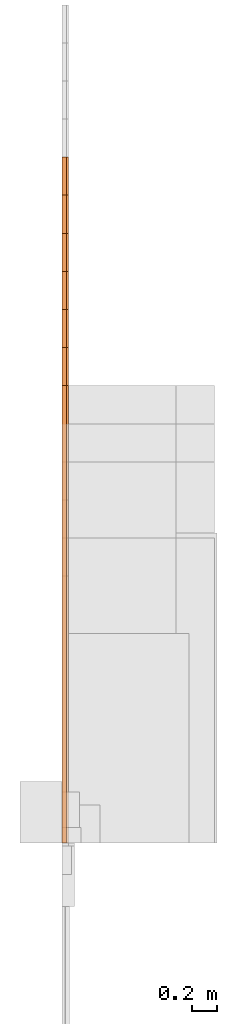
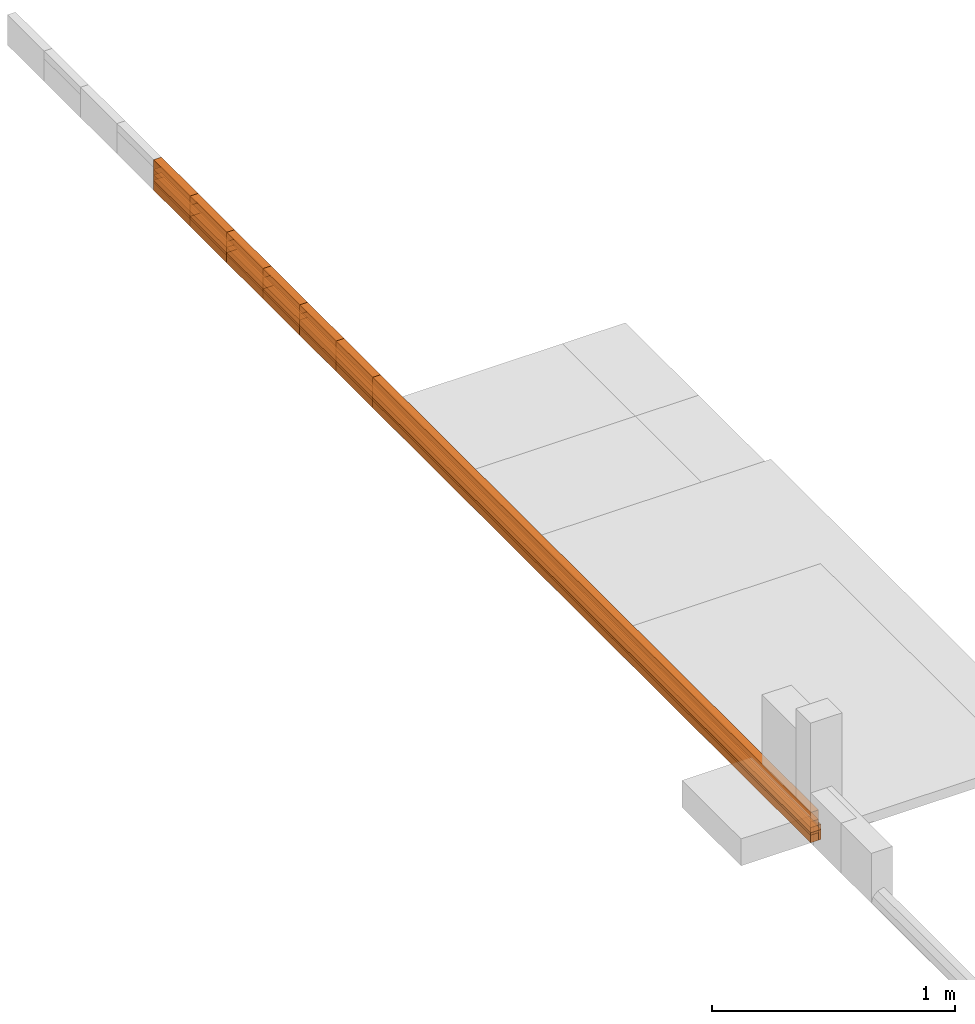
# Not in any storey, part 3 of 5: 43 proxies.
"""IFC4 model written with IfcOpenShell, lengths in metres."""

from ifc_helpers import new_model, entity, si_unit, converted_unit, direction, origin_with_axes, place, context, subcontext, project, faceted_brep, element, save


model = new_model("IFC4")

# Units and contexts
model_context = context("Model", 3, precision=1e-05, world=origin_with_axes(), true_north=direction((0.0, 1.0)))
body_context = subcontext(model_context, "Body", "Model", "MODEL_VIEW")
ifc_project = project(units=[si_unit("LENGTHUNIT", "METRE"), si_unit("AREAUNIT", "SQUARE_METRE"), si_unit("VOLUMEUNIT", "CUBIC_METRE"), converted_unit("PLANEANGLEUNIT", "DEGREE", entity("IfcPlaneAngleMeasure", 0.017453292519943295), si_unit("PLANEANGLEUNIT", "RADIAN"), dimensions=[0, 0, 0, 0, 0, 0, 0])], contexts=[model_context])

# Proxies
proxy_1_placement = place(None, origin_with_axes())
element("IfcBuildingElementProxy", 1, at=proxy_1_placement, Name="Timber 38x105x3900", context=body_context, shape_type="Brep", body=[
    faceted_brep([(0.038, 0.0, 0.0), (0.038, 0.0, 0.105), (0.0, 0.0, 0.105), (0.0, 0.0, 0.0), (0.038, 3.9, 0.0), (0.038, 3.9, 0.105), (0.038, 0.0, 0.105), (0.038, 0.0, 0.0), (0.0, 3.9, 0.0), (0.0, 3.9, 0.105), (0.038, 3.9, 0.105), (0.038, 3.9, 0.0), (0.0, 0.0, 0.0), (0.0, 0.0, 0.105), (0.0, 3.9, 0.105), (0.0, 3.9, 0.0), (0.0, 3.9, 0.0), (0.038, 3.9, 0.0), (0.038, 0.0, 0.0), (0.0, 0.0, 0.0), (0.0, 0.0, 0.105), (0.038, 0.0, 0.105), (0.038, 3.9, 0.105), (0.0, 3.9, 0.105)], [[[0, 1, 2, 3]], [[4, 5, 6, 7]], [[8, 9, 10, 11]], [[12, 13, 14, 15]], [[16, 17, 18, 19]], [[20, 21, 22, 23]]]),
])
proxy_2_placement = place(None, origin_with_axes())
element("IfcBuildingElementProxy", 2, at=proxy_2_placement, Name="Timber 38x105x4200", context=body_context, shape_type="Brep", body=[
    faceted_brep([(0.0, 4.2, 0.0), (0.0, 4.2, 0.105), (0.038, 4.2, 0.105), (0.038, 4.2, 0.0), (0.038, 4.2, 0.0), (0.038, 4.2, 0.105), (0.038, 0.0, 0.105), (0.038, 0.0, 0.0), (0.038, 0.0, 0.0), (0.038, 0.0, 0.105), (0.0, 0.0, 0.105), (0.0, 0.0, 0.0), (0.0, 0.0, 0.0), (0.0, 0.0, 0.105), (0.0, 4.2, 0.105), (0.0, 4.2, 0.0), (0.038, 0.0, 0.0), (0.0, 0.0, 0.0), (0.0, 4.2, 0.0), (0.038, 4.2, 0.0), (0.038, 4.2, 0.105), (0.0, 4.2, 0.105), (0.0, 0.0, 0.105), (0.038, 0.0, 0.105)], [[[0, 1, 2, 3]], [[4, 5, 6, 7]], [[8, 9, 10, 11]], [[12, 13, 14, 15]], [[16, 17, 18, 19]], [[20, 21, 22, 23]]]),
])
proxy_3_placement = place(None, origin_with_axes())
element("IfcBuildingElementProxy", 3, at=proxy_3_placement, Name="Timber 38x105x4500", context=body_context, shape_type="Brep", body=[
    faceted_brep([(0.038, 0.0, 0.0), (0.038, 0.0, 0.105), (0.0, 0.0, 0.105), (0.0, 0.0, 0.0), (0.038, 4.5, 0.0), (0.038, 4.5, 0.105), (0.038, 0.0, 0.105), (0.038, 0.0, 0.0), (0.0, 4.5, 0.0), (0.0, 4.5, 0.105), (0.038, 4.5, 0.105), (0.038, 4.5, 0.0), (0.0, 0.0, 0.0), (0.0, 0.0, 0.105), (0.0, 4.5, 0.105), (0.0, 4.5, 0.0), (0.0, 4.5, 0.0), (0.038, 4.5, 0.0), (0.038, 0.0, 0.0), (0.0, 0.0, 0.0), (0.0, 0.0, 0.105), (0.038, 0.0, 0.105), (0.038, 4.5, 0.105), (0.0, 4.5, 0.105)], [[[0, 1, 2, 3]], [[4, 5, 6, 7]], [[8, 9, 10, 11]], [[12, 13, 14, 15]], [[16, 17, 18, 19]], [[20, 21, 22, 23]]]),
])
proxy_4_placement = place(None, origin_with_axes())
element("IfcBuildingElementProxy", 4, at=proxy_4_placement, Name="Timber 38x105x4800", context=body_context, shape_type="Brep", body=[
    faceted_brep([(0.038, 0.0, 0.0), (0.038, 0.0, 0.105), (0.0, 0.0, 0.105), (0.0, 0.0, 0.0), (0.038, 4.8, 0.0), (0.038, 4.8, 0.105), (0.038, 0.0, 0.105), (0.038, 0.0, 0.0), (0.0, 4.8, 0.0), (0.0, 4.8, 0.105), (0.038, 4.8, 0.105), (0.038, 4.8, 0.0), (0.0, 0.0, 0.0), (0.0, 0.0, 0.105), (0.0, 4.8, 0.105), (0.0, 4.8, 0.0), (0.0, 4.8, 0.0), (0.038, 4.8, 0.0), (0.038, 0.0, 0.0), (0.0, 0.0, 0.0), (0.0, 0.0, 0.105), (0.038, 0.0, 0.105), (0.038, 4.8, 0.105), (0.0, 4.8, 0.105)], [[[0, 1, 2, 3]], [[4, 5, 6, 7]], [[8, 9, 10, 11]], [[12, 13, 14, 15]], [[16, 17, 18, 19]], [[20, 21, 22, 23]]]),
])
proxy_5_placement = place(None, origin_with_axes())
element("IfcBuildingElementProxy", 5, at=proxy_5_placement, Name="Timber 38x105x5100", context=body_context, shape_type="Brep", body=[
    faceted_brep([(0.038, 0.0, 0.0), (0.038, 0.0, 0.105), (0.0, 0.0, 0.105), (0.0, 0.0, 0.0), (0.038, 5.1, 0.0), (0.038, 5.1, 0.105), (0.038, 0.0, 0.105), (0.038, 0.0, 0.0), (0.0, 5.1, 0.0), (0.0, 5.1, 0.105), (0.038, 5.1, 0.105), (0.038, 5.1, 0.0), (0.0, 0.0, 0.0), (0.0, 0.0, 0.105), (0.0, 5.1, 0.105), (0.0, 5.1, 0.0), (0.0, 5.1, 0.0), (0.038, 5.1, 0.0), (0.038, 0.0, 0.0), (0.0, 0.0, 0.0), (0.0, 0.0, 0.105), (0.038, 0.0, 0.105), (0.038, 5.1, 0.105), (0.0, 5.1, 0.105)], [[[0, 1, 2, 3]], [[4, 5, 6, 7]], [[8, 9, 10, 11]], [[12, 13, 14, 15]], [[16, 17, 18, 19]], [[20, 21, 22, 23]]]),
])
proxy_6_placement = place(None, origin_with_axes())
element("IfcBuildingElementProxy", 6, at=proxy_6_placement, Name="Timber 38x105x5400", context=body_context, shape_type="Brep", body=[
    faceted_brep([(0.038, 0.0, 0.0), (0.038, 0.0, 0.105), (0.0, 0.0, 0.105), (0.0, 0.0, 0.0), (0.038, 5.4, 0.0), (0.038, 5.4, 0.105), (0.038, 0.0, 0.105), (0.038, 0.0, 0.0), (0.0, 5.4, 0.0), (0.0, 5.4, 0.105), (0.038, 5.4, 0.105), (0.038, 5.4, 0.0), (0.0, 0.0, 0.0), (0.0, 0.0, 0.105), (0.0, 5.4, 0.105), (0.0, 5.4, 0.0), (0.0, 5.4, 0.0), (0.038, 5.4, 0.0), (0.038, 0.0, 0.0), (0.0, 0.0, 0.0), (0.0, 0.0, 0.105), (0.038, 0.0, 0.105), (0.038, 5.4, 0.105), (0.0, 5.4, 0.105)], [[[0, 1, 2, 3]], [[4, 5, 6, 7]], [[8, 9, 10, 11]], [[12, 13, 14, 15]], [[16, 17, 18, 19]], [[20, 21, 22, 23]]]),
])
proxy_7_placement = place(None, origin_with_axes())
element("IfcBuildingElementProxy", 7, at=proxy_7_placement, Name="Timber 38x38x3600", context=body_context, shape_type="Brep", body=[
    faceted_brep([(0.0, 3.6, 0.0), (0.0, 3.6, 0.038), (0.038, 3.6, 0.038), (0.038, 3.6, 0.0), (0.038, 3.6, 0.0), (0.038, 3.6, 0.038), (0.038, 0.0, 0.038), (0.038, 0.0, 0.0), (0.038, 0.0, 0.0), (0.038, 0.0, 0.038), (0.0, 0.0, 0.038), (0.0, 0.0, 0.0), (0.0, 0.0, 0.0), (0.0, 0.0, 0.038), (0.0, 3.6, 0.038), (0.0, 3.6, 0.0), (0.038, 0.0, 0.0), (0.0, 0.0, 0.0), (0.0, 3.6, 0.0), (0.038, 3.6, 0.0), (0.038, 3.6, 0.038), (0.0, 3.6, 0.038), (0.0, 0.0, 0.038), (0.038, 0.0, 0.038)], [[[0, 1, 2, 3]], [[4, 5, 6, 7]], [[8, 9, 10, 11]], [[12, 13, 14, 15]], [[16, 17, 18, 19]], [[20, 21, 22, 23]]]),
])
proxy_8_placement = place(None, origin_with_axes())
element("IfcBuildingElementProxy", 8, at=proxy_8_placement, Name="Timber 38x38x3900", context=body_context, shape_type="Brep", body=[
    faceted_brep([(0.038, 0.0, 0.0), (0.038, 0.0, 0.038), (0.0, 0.0, 0.038), (0.0, 0.0, 0.0), (0.038, 3.9, 0.0), (0.038, 3.9, 0.038), (0.038, 0.0, 0.038), (0.038, 0.0, 0.0), (0.0, 3.9, 0.0), (0.0, 3.9, 0.038), (0.038, 3.9, 0.038), (0.038, 3.9, 0.0), (0.0, 0.0, 0.0), (0.0, 0.0, 0.038), (0.0, 3.9, 0.038), (0.0, 3.9, 0.0), (0.0, 3.9, 0.0), (0.038, 3.9, 0.0), (0.038, 0.0, 0.0), (0.0, 0.0, 0.0), (0.0, 0.0, 0.038), (0.038, 0.0, 0.038), (0.038, 3.9, 0.038), (0.0, 3.9, 0.038)], [[[0, 1, 2, 3]], [[4, 5, 6, 7]], [[8, 9, 10, 11]], [[12, 13, 14, 15]], [[16, 17, 18, 19]], [[20, 21, 22, 23]]]),
])
proxy_9_placement = place(None, origin_with_axes())
element("IfcBuildingElementProxy", 9, at=proxy_9_placement, Name="Timber 38x38x4200", context=body_context, shape_type="Brep", body=[
    faceted_brep([(0.0, 4.2, 0.0), (0.0, 4.2, 0.038), (0.038, 4.2, 0.038), (0.038, 4.2, 0.0), (0.038, 4.2, 0.0), (0.038, 4.2, 0.038), (0.038, 0.0, 0.038), (0.038, 0.0, 0.0), (0.038, 0.0, 0.0), (0.038, 0.0, 0.038), (0.0, 0.0, 0.038), (0.0, 0.0, 0.0), (0.0, 0.0, 0.0), (0.0, 0.0, 0.038), (0.0, 4.2, 0.038), (0.0, 4.2, 0.0), (0.038, 0.0, 0.0), (0.0, 0.0, 0.0), (0.0, 4.2, 0.0), (0.038, 4.2, 0.0), (0.038, 4.2, 0.038), (0.0, 4.2, 0.038), (0.0, 0.0, 0.038), (0.038, 0.0, 0.038)], [[[0, 1, 2, 3]], [[4, 5, 6, 7]], [[8, 9, 10, 11]], [[12, 13, 14, 15]], [[16, 17, 18, 19]], [[20, 21, 22, 23]]]),
])
proxy_10_placement = place(None, origin_with_axes())
element("IfcBuildingElementProxy", 10, at=proxy_10_placement, Name="Timber 38x38x4500", context=body_context, shape_type="Brep", body=[
    faceted_brep([(0.038, 0.0, 0.0), (0.038, 0.0, 0.038), (0.0, 0.0, 0.038), (0.0, 0.0, 0.0), (0.038, 4.5, 0.0), (0.038, 4.5, 0.038), (0.038, 0.0, 0.038), (0.038, 0.0, 0.0), (0.0, 4.5, 0.0), (0.0, 4.5, 0.038), (0.038, 4.5, 0.038), (0.038, 4.5, 0.0), (0.0, 0.0, 0.0), (0.0, 0.0, 0.038), (0.0, 4.5, 0.038), (0.0, 4.5, 0.0), (0.0, 4.5, 0.0), (0.038, 4.5, 0.0), (0.038, 0.0, 0.0), (0.0, 0.0, 0.0), (0.0, 0.0, 0.038), (0.038, 0.0, 0.038), (0.038, 4.5, 0.038), (0.0, 4.5, 0.038)], [[[0, 1, 2, 3]], [[4, 5, 6, 7]], [[8, 9, 10, 11]], [[12, 13, 14, 15]], [[16, 17, 18, 19]], [[20, 21, 22, 23]]]),
])
proxy_11_placement = place(None, origin_with_axes())
element("IfcBuildingElementProxy", 11, at=proxy_11_placement, Name="Timber 38x38x4800", context=body_context, shape_type="Brep", body=[
    faceted_brep([(0.038, 0.0, 0.0), (0.038, 0.0, 0.038), (0.0, 0.0, 0.038), (0.0, 0.0, 0.0), (0.038, 4.8, 0.0), (0.038, 4.8, 0.038), (0.038, 0.0, 0.038), (0.038, 0.0, 0.0), (0.0, 4.8, 0.0), (0.0, 4.8, 0.038), (0.038, 4.8, 0.038), (0.038, 4.8, 0.0), (0.0, 0.0, 0.0), (0.0, 0.0, 0.038), (0.0, 4.8, 0.038), (0.0, 4.8, 0.0), (0.0, 4.8, 0.0), (0.038, 4.8, 0.0), (0.038, 0.0, 0.0), (0.0, 0.0, 0.0), (0.0, 0.0, 0.038), (0.038, 0.0, 0.038), (0.038, 4.8, 0.038), (0.0, 4.8, 0.038)], [[[0, 1, 2, 3]], [[4, 5, 6, 7]], [[8, 9, 10, 11]], [[12, 13, 14, 15]], [[16, 17, 18, 19]], [[20, 21, 22, 23]]]),
])
proxy_12_placement = place(None, origin_with_axes())
element("IfcBuildingElementProxy", 12, at=proxy_12_placement, Name="Timber 38x38x5100", context=body_context, shape_type="Brep", body=[
    faceted_brep([(0.038, 0.0, 0.0), (0.038, 0.0, 0.038), (0.0, 0.0, 0.038), (0.0, 0.0, 0.0), (0.038, 5.1, 0.0), (0.038, 5.1, 0.038), (0.038, 0.0, 0.038), (0.038, 0.0, 0.0), (0.0, 5.1, 0.0), (0.0, 5.1, 0.038), (0.038, 5.1, 0.038), (0.038, 5.1, 0.0), (0.0, 0.0, 0.0), (0.0, 0.0, 0.038), (0.0, 5.1, 0.038), (0.0, 5.1, 0.0), (0.0, 5.1, 0.0), (0.038, 5.1, 0.0), (0.038, 0.0, 0.0), (0.0, 0.0, 0.0), (0.0, 0.0, 0.038), (0.038, 0.0, 0.038), (0.038, 5.1, 0.038), (0.0, 5.1, 0.038)], [[[0, 1, 2, 3]], [[4, 5, 6, 7]], [[8, 9, 10, 11]], [[12, 13, 14, 15]], [[16, 17, 18, 19]], [[20, 21, 22, 23]]]),
])
proxy_13_placement = place(None, origin_with_axes())
element("IfcBuildingElementProxy", 13, at=proxy_13_placement, Name="Timber 38x38x5400", context=body_context, shape_type="Brep", body=[
    faceted_brep([(0.038, 0.0, 0.0), (0.038, 0.0, 0.038), (0.0, 0.0, 0.038), (0.0, 0.0, 0.0), (0.038, 5.4, 0.0), (0.038, 5.4, 0.038), (0.038, 0.0, 0.038), (0.038, 0.0, 0.0), (0.0, 5.4, 0.0), (0.0, 5.4, 0.038), (0.038, 5.4, 0.038), (0.038, 5.4, 0.0), (0.0, 0.0, 0.0), (0.0, 0.0, 0.038), (0.0, 5.4, 0.038), (0.0, 5.4, 0.0), (0.0, 5.4, 0.0), (0.038, 5.4, 0.0), (0.038, 0.0, 0.0), (0.0, 0.0, 0.0), (0.0, 0.0, 0.038), (0.038, 0.0, 0.038), (0.038, 5.4, 0.038), (0.0, 5.4, 0.038)], [[[0, 1, 2, 3]], [[4, 5, 6, 7]], [[8, 9, 10, 11]], [[12, 13, 14, 15]], [[16, 17, 18, 19]], [[20, 21, 22, 23]]]),
])
proxy_14_placement = place(None, origin_with_axes())
element("IfcBuildingElementProxy", 14, at=proxy_14_placement, Name="Timber 38x50x3600", context=body_context, shape_type="Brep", body=[
    faceted_brep([(0.0, 3.6, 0.0), (0.0, 3.6, 0.05), (0.038, 3.6, 0.05), (0.038, 3.6, 0.0), (0.038, 3.6, 0.0), (0.038, 3.6, 0.05), (0.038, 0.0, 0.05), (0.038, 0.0, 0.0), (0.038, 0.0, 0.0), (0.038, 0.0, 0.05), (0.0, 0.0, 0.05), (0.0, 0.0, 0.0), (0.0, 0.0, 0.0), (0.0, 0.0, 0.05), (0.0, 3.6, 0.05), (0.0, 3.6, 0.0), (0.038, 0.0, 0.0), (0.0, 0.0, 0.0), (0.0, 3.6, 0.0), (0.038, 3.6, 0.0), (0.038, 3.6, 0.05), (0.0, 3.6, 0.05), (0.0, 0.0, 0.05), (0.038, 0.0, 0.05)], [[[0, 1, 2, 3]], [[4, 5, 6, 7]], [[8, 9, 10, 11]], [[12, 13, 14, 15]], [[16, 17, 18, 19]], [[20, 21, 22, 23]]]),
])
proxy_15_placement = place(None, origin_with_axes())
element("IfcBuildingElementProxy", 15, at=proxy_15_placement, Name="Timber 38x50x3900", context=body_context, shape_type="Brep", body=[
    faceted_brep([(0.038, 0.0, 0.0), (0.038, 0.0, 0.05), (0.0, 0.0, 0.05), (0.0, 0.0, 0.0), (0.038, 3.9, 0.0), (0.038, 3.9, 0.05), (0.038, 0.0, 0.05), (0.038, 0.0, 0.0), (0.0, 3.9, 0.0), (0.0, 3.9, 0.05), (0.038, 3.9, 0.05), (0.038, 3.9, 0.0), (0.0, 0.0, 0.0), (0.0, 0.0, 0.05), (0.0, 3.9, 0.05), (0.0, 3.9, 0.0), (0.0, 3.9, 0.0), (0.038, 3.9, 0.0), (0.038, 0.0, 0.0), (0.0, 0.0, 0.0), (0.0, 0.0, 0.05), (0.038, 0.0, 0.05), (0.038, 3.9, 0.05), (0.0, 3.9, 0.05)], [[[0, 1, 2, 3]], [[4, 5, 6, 7]], [[8, 9, 10, 11]], [[12, 13, 14, 15]], [[16, 17, 18, 19]], [[20, 21, 22, 23]]]),
])
proxy_16_placement = place(None, origin_with_axes())
element("IfcBuildingElementProxy", 16, at=proxy_16_placement, Name="Timber 38x50x4200", context=body_context, shape_type="Brep", body=[
    faceted_brep([(0.0, 4.2, 0.0), (0.0, 4.2, 0.05), (0.038, 4.2, 0.05), (0.038, 4.2, 0.0), (0.038, 4.2, 0.0), (0.038, 4.2, 0.05), (0.038, 0.0, 0.05), (0.038, 0.0, 0.0), (0.038, 0.0, 0.0), (0.038, 0.0, 0.05), (0.0, 0.0, 0.05), (0.0, 0.0, 0.0), (0.0, 0.0, 0.0), (0.0, 0.0, 0.05), (0.0, 4.2, 0.05), (0.0, 4.2, 0.0), (0.038, 0.0, 0.0), (0.0, 0.0, 0.0), (0.0, 4.2, 0.0), (0.038, 4.2, 0.0), (0.038, 4.2, 0.05), (0.0, 4.2, 0.05), (0.0, 0.0, 0.05), (0.038, 0.0, 0.05)], [[[0, 1, 2, 3]], [[4, 5, 6, 7]], [[8, 9, 10, 11]], [[12, 13, 14, 15]], [[16, 17, 18, 19]], [[20, 21, 22, 23]]]),
])
proxy_17_placement = place(None, origin_with_axes())
element("IfcBuildingElementProxy", 17, at=proxy_17_placement, Name="Timber 38x50x4500", context=body_context, shape_type="Brep", body=[
    faceted_brep([(0.038, 0.0, 0.0), (0.038, 0.0, 0.05), (0.0, 0.0, 0.05), (0.0, 0.0, 0.0), (0.038, 4.5, 0.0), (0.038, 4.5, 0.05), (0.038, 0.0, 0.05), (0.038, 0.0, 0.0), (0.0, 4.5, 0.0), (0.0, 4.5, 0.05), (0.038, 4.5, 0.05), (0.038, 4.5, 0.0), (0.0, 0.0, 0.0), (0.0, 0.0, 0.05), (0.0, 4.5, 0.05), (0.0, 4.5, 0.0), (0.0, 4.5, 0.0), (0.038, 4.5, 0.0), (0.038, 0.0, 0.0), (0.0, 0.0, 0.0), (0.0, 0.0, 0.05), (0.038, 0.0, 0.05), (0.038, 4.5, 0.05), (0.0, 4.5, 0.05)], [[[0, 1, 2, 3]], [[4, 5, 6, 7]], [[8, 9, 10, 11]], [[12, 13, 14, 15]], [[16, 17, 18, 19]], [[20, 21, 22, 23]]]),
])
proxy_18_placement = place(None, origin_with_axes())
element("IfcBuildingElementProxy", 18, at=proxy_18_placement, Name="Timber 38x50x4800", context=body_context, shape_type="Brep", body=[
    faceted_brep([(0.038, 0.0, 0.0), (0.038, 0.0, 0.05), (0.0, 0.0, 0.05), (0.0, 0.0, 0.0), (0.038, 4.8, 0.0), (0.038, 4.8, 0.05), (0.038, 0.0, 0.05), (0.038, 0.0, 0.0), (0.0, 4.8, 0.0), (0.0, 4.8, 0.05), (0.038, 4.8, 0.05), (0.038, 4.8, 0.0), (0.0, 0.0, 0.0), (0.0, 0.0, 0.05), (0.0, 4.8, 0.05), (0.0, 4.8, 0.0), (0.0, 4.8, 0.0), (0.038, 4.8, 0.0), (0.038, 0.0, 0.0), (0.0, 0.0, 0.0), (0.0, 0.0, 0.05), (0.038, 0.0, 0.05), (0.038, 4.8, 0.05), (0.0, 4.8, 0.05)], [[[0, 1, 2, 3]], [[4, 5, 6, 7]], [[8, 9, 10, 11]], [[12, 13, 14, 15]], [[16, 17, 18, 19]], [[20, 21, 22, 23]]]),
])
proxy_19_placement = place(None, origin_with_axes())
element("IfcBuildingElementProxy", 19, at=proxy_19_placement, Name="Timber 38x50x5100", context=body_context, shape_type="Brep", body=[
    faceted_brep([(0.038, 0.0, 0.0), (0.038, 0.0, 0.05), (0.0, 0.0, 0.05), (0.0, 0.0, 0.0), (0.038, 5.1, 0.0), (0.038, 5.1, 0.05), (0.038, 0.0, 0.05), (0.038, 0.0, 0.0), (0.0, 5.1, 0.0), (0.0, 5.1, 0.05), (0.038, 5.1, 0.05), (0.038, 5.1, 0.0), (0.0, 0.0, 0.0), (0.0, 0.0, 0.05), (0.0, 5.1, 0.05), (0.0, 5.1, 0.0), (0.0, 5.1, 0.0), (0.038, 5.1, 0.0), (0.038, 0.0, 0.0), (0.0, 0.0, 0.0), (0.0, 0.0, 0.05), (0.038, 0.0, 0.05), (0.038, 5.1, 0.05), (0.0, 5.1, 0.05)], [[[0, 1, 2, 3]], [[4, 5, 6, 7]], [[8, 9, 10, 11]], [[12, 13, 14, 15]], [[16, 17, 18, 19]], [[20, 21, 22, 23]]]),
])
proxy_20_placement = place(None, origin_with_axes())
element("IfcBuildingElementProxy", 20, at=proxy_20_placement, Name="Timber 38x50x5400", context=body_context, shape_type="Brep", body=[
    faceted_brep([(0.038, 0.0, 0.0), (0.038, 0.0, 0.05), (0.0, 0.0, 0.05), (0.0, 0.0, 0.0), (0.038, 5.4, 0.0), (0.038, 5.4, 0.05), (0.038, 0.0, 0.05), (0.038, 0.0, 0.0), (0.0, 5.4, 0.0), (0.0, 5.4, 0.05), (0.038, 5.4, 0.05), (0.038, 5.4, 0.0), (0.0, 0.0, 0.0), (0.0, 0.0, 0.05), (0.0, 5.4, 0.05), (0.0, 5.4, 0.0), (0.0, 5.4, 0.0), (0.038, 5.4, 0.0), (0.038, 0.0, 0.0), (0.0, 0.0, 0.0), (0.0, 0.0, 0.05), (0.038, 0.0, 0.05), (0.038, 5.4, 0.05), (0.0, 5.4, 0.05)], [[[0, 1, 2, 3]], [[4, 5, 6, 7]], [[8, 9, 10, 11]], [[12, 13, 14, 15]], [[16, 17, 18, 19]], [[20, 21, 22, 23]]]),
])
proxy_21_placement = place(None, origin_with_axes())
element("IfcBuildingElementProxy", 21, at=proxy_21_placement, Name="Timber 38x152x3600", context=body_context, shape_type="Brep", body=[
    faceted_brep([(0.0, 3.6, 0.0), (0.0, 3.6, 0.152), (0.038, 3.6, 0.152), (0.038, 3.6, 0.0), (0.038, 3.6, 0.0), (0.038, 3.6, 0.152), (0.038, 0.0, 0.152), (0.038, 0.0, 0.0), (0.038, 0.0, 0.0), (0.038, 0.0, 0.152), (0.0, 0.0, 0.152), (0.0, 0.0, 0.0), (0.0, 0.0, 0.0), (0.0, 0.0, 0.152), (0.0, 3.6, 0.152), (0.0, 3.6, 0.0), (0.038, 0.0, 0.0), (0.0, 0.0, 0.0), (0.0, 3.6, 0.0), (0.038, 3.6, 0.0), (0.038, 3.6, 0.152), (0.0, 3.6, 0.152), (0.0, 0.0, 0.152), (0.038, 0.0, 0.152)], [[[0, 1, 2, 3]], [[4, 5, 6, 7]], [[8, 9, 10, 11]], [[12, 13, 14, 15]], [[16, 17, 18, 19]], [[20, 21, 22, 23]]]),
])
proxy_22_placement = place(None, origin_with_axes())
element("IfcBuildingElementProxy", 22, at=proxy_22_placement, Name="Timber 38x152x3900", context=body_context, shape_type="Brep", body=[
    faceted_brep([(0.038, 0.0, 0.0), (0.038, 0.0, 0.152), (0.0, 0.0, 0.152), (0.0, 0.0, 0.0), (0.038, 3.9, 0.0), (0.038, 3.9, 0.152), (0.038, 0.0, 0.152), (0.038, 0.0, 0.0), (0.0, 3.9, 0.0), (0.0, 3.9, 0.152), (0.038, 3.9, 0.152), (0.038, 3.9, 0.0), (0.0, 0.0, 0.0), (0.0, 0.0, 0.152), (0.0, 3.9, 0.152), (0.0, 3.9, 0.0), (0.0, 3.9, 0.0), (0.038, 3.9, 0.0), (0.038, 0.0, 0.0), (0.0, 0.0, 0.0), (0.0, 0.0, 0.152), (0.038, 0.0, 0.152), (0.038, 3.9, 0.152), (0.0, 3.9, 0.152)], [[[0, 1, 2, 3]], [[4, 5, 6, 7]], [[8, 9, 10, 11]], [[12, 13, 14, 15]], [[16, 17, 18, 19]], [[20, 21, 22, 23]]]),
])
proxy_23_placement = place(None, origin_with_axes())
element("IfcBuildingElementProxy", 23, at=proxy_23_placement, Name="Timber 38x152x4200", context=body_context, shape_type="Brep", body=[
    faceted_brep([(0.0, 4.2, 0.0), (0.0, 4.2, 0.152), (0.038, 4.2, 0.152), (0.038, 4.2, 0.0), (0.038, 4.2, 0.0), (0.038, 4.2, 0.152), (0.038, 0.0, 0.152), (0.038, 0.0, 0.0), (0.038, 0.0, 0.0), (0.038, 0.0, 0.152), (0.0, 0.0, 0.152), (0.0, 0.0, 0.0), (0.0, 0.0, 0.0), (0.0, 0.0, 0.152), (0.0, 4.2, 0.152), (0.0, 4.2, 0.0), (0.038, 0.0, 0.0), (0.0, 0.0, 0.0), (0.0, 4.2, 0.0), (0.038, 4.2, 0.0), (0.038, 4.2, 0.152), (0.0, 4.2, 0.152), (0.0, 0.0, 0.152), (0.038, 0.0, 0.152)], [[[0, 1, 2, 3]], [[4, 5, 6, 7]], [[8, 9, 10, 11]], [[12, 13, 14, 15]], [[16, 17, 18, 19]], [[20, 21, 22, 23]]]),
])
proxy_24_placement = place(None, origin_with_axes())
element("IfcBuildingElementProxy", 24, at=proxy_24_placement, Name="Timber 38x152x4500", context=body_context, shape_type="Brep", body=[
    faceted_brep([(0.038, 0.0, 0.0), (0.038, 0.0, 0.152), (0.0, 0.0, 0.152), (0.0, 0.0, 0.0), (0.038, 4.5, 0.0), (0.038, 4.5, 0.152), (0.038, 0.0, 0.152), (0.038, 0.0, 0.0), (0.0, 4.5, 0.0), (0.0, 4.5, 0.152), (0.038, 4.5, 0.152), (0.038, 4.5, 0.0), (0.0, 0.0, 0.0), (0.0, 0.0, 0.152), (0.0, 4.5, 0.152), (0.0, 4.5, 0.0), (0.0, 4.5, 0.0), (0.038, 4.5, 0.0), (0.038, 0.0, 0.0), (0.0, 0.0, 0.0), (0.0, 0.0, 0.152), (0.038, 0.0, 0.152), (0.038, 4.5, 0.152), (0.0, 4.5, 0.152)], [[[0, 1, 2, 3]], [[4, 5, 6, 7]], [[8, 9, 10, 11]], [[12, 13, 14, 15]], [[16, 17, 18, 19]], [[20, 21, 22, 23]]]),
])
proxy_25_placement = place(None, origin_with_axes())
element("IfcBuildingElementProxy", 25, at=proxy_25_placement, Name="Timber 38x152x4800", context=body_context, shape_type="Brep", body=[
    faceted_brep([(0.038, 0.0, 0.0), (0.038, 0.0, 0.152), (0.0, 0.0, 0.152), (0.0, 0.0, 0.0), (0.038, 4.8, 0.0), (0.038, 4.8, 0.152), (0.038, 0.0, 0.152), (0.038, 0.0, 0.0), (0.0, 4.8, 0.0), (0.0, 4.8, 0.152), (0.038, 4.8, 0.152), (0.038, 4.8, 0.0), (0.0, 0.0, 0.0), (0.0, 0.0, 0.152), (0.0, 4.8, 0.152), (0.0, 4.8, 0.0), (0.0, 4.8, 0.0), (0.038, 4.8, 0.0), (0.038, 0.0, 0.0), (0.0, 0.0, 0.0), (0.0, 0.0, 0.152), (0.038, 0.0, 0.152), (0.038, 4.8, 0.152), (0.0, 4.8, 0.152)], [[[0, 1, 2, 3]], [[4, 5, 6, 7]], [[8, 9, 10, 11]], [[12, 13, 14, 15]], [[16, 17, 18, 19]], [[20, 21, 22, 23]]]),
])
proxy_26_placement = place(None, origin_with_axes())
element("IfcBuildingElementProxy", 26, at=proxy_26_placement, Name="Timber 38x152x5100", context=body_context, shape_type="Brep", body=[
    faceted_brep([(0.038, 0.0, 0.0), (0.038, 0.0, 0.152), (0.0, 0.0, 0.152), (0.0, 0.0, 0.0), (0.038, 5.1, 0.0), (0.038, 5.1, 0.152), (0.038, 0.0, 0.152), (0.038, 0.0, 0.0), (0.0, 5.1, 0.0), (0.0, 5.1, 0.152), (0.038, 5.1, 0.152), (0.038, 5.1, 0.0), (0.0, 0.0, 0.0), (0.0, 0.0, 0.152), (0.0, 5.1, 0.152), (0.0, 5.1, 0.0), (0.0, 5.1, 0.0), (0.038, 5.1, 0.0), (0.038, 0.0, 0.0), (0.0, 0.0, 0.0), (0.0, 0.0, 0.152), (0.038, 0.0, 0.152), (0.038, 5.1, 0.152), (0.0, 5.1, 0.152)], [[[0, 1, 2, 3]], [[4, 5, 6, 7]], [[8, 9, 10, 11]], [[12, 13, 14, 15]], [[16, 17, 18, 19]], [[20, 21, 22, 23]]]),
])
proxy_27_placement = place(None, origin_with_axes())
element("IfcBuildingElementProxy", 27, at=proxy_27_placement, Name="Timber 38x152x5400", context=body_context, shape_type="Brep", body=[
    faceted_brep([(0.038, 0.0, 0.0), (0.038, 0.0, 0.152), (0.0, 0.0, 0.152), (0.0, 0.0, 0.0), (0.038, 5.4, 0.0), (0.038, 5.4, 0.152), (0.038, 0.0, 0.152), (0.038, 0.0, 0.0), (0.0, 5.4, 0.0), (0.0, 5.4, 0.152), (0.038, 5.4, 0.152), (0.038, 5.4, 0.0), (0.0, 0.0, 0.0), (0.0, 0.0, 0.152), (0.0, 5.4, 0.152), (0.0, 5.4, 0.0), (0.0, 5.4, 0.0), (0.038, 5.4, 0.0), (0.038, 0.0, 0.0), (0.0, 0.0, 0.0), (0.0, 0.0, 0.152), (0.038, 0.0, 0.152), (0.038, 5.4, 0.152), (0.0, 5.4, 0.152)], [[[0, 1, 2, 3]], [[4, 5, 6, 7]], [[8, 9, 10, 11]], [[12, 13, 14, 15]], [[16, 17, 18, 19]], [[20, 21, 22, 23]]]),
])
proxy_28_placement = place(None, origin_with_axes())
element("IfcBuildingElementProxy", 28, at=proxy_28_placement, Name="Timber 38x76x3600", context=body_context, shape_type="Brep", body=[
    faceted_brep([(0.0, 3.6, 0.0), (0.0, 3.6, 0.076), (0.038, 3.6, 0.076), (0.038, 3.6, 0.0), (0.038, 3.6, 0.0), (0.038, 3.6, 0.076), (0.038, 0.0, 0.076), (0.038, 0.0, 0.0), (0.038, 0.0, 0.0), (0.038, 0.0, 0.076), (0.0, 0.0, 0.076), (0.0, 0.0, 0.0), (0.0, 0.0, 0.0), (0.0, 0.0, 0.076), (0.0, 3.6, 0.076), (0.0, 3.6, 0.0), (0.038, 0.0, 0.0), (0.0, 0.0, 0.0), (0.0, 3.6, 0.0), (0.038, 3.6, 0.0), (0.038, 3.6, 0.076), (0.0, 3.6, 0.076), (0.0, 0.0, 0.076), (0.038, 0.0, 0.076)], [[[0, 1, 2, 3]], [[4, 5, 6, 7]], [[8, 9, 10, 11]], [[12, 13, 14, 15]], [[16, 17, 18, 19]], [[20, 21, 22, 23]]]),
])
proxy_29_placement = place(None, origin_with_axes())
element("IfcBuildingElementProxy", 29, at=proxy_29_placement, Name="Timber 38x76x3900", context=body_context, shape_type="Brep", body=[
    faceted_brep([(0.038, 0.0, 0.0), (0.038, 0.0, 0.076), (0.0, 0.0, 0.076), (0.0, 0.0, 0.0), (0.038, 3.9, 0.0), (0.038, 3.9, 0.076), (0.038, 0.0, 0.076), (0.038, 0.0, 0.0), (0.0, 3.9, 0.0), (0.0, 3.9, 0.076), (0.038, 3.9, 0.076), (0.038, 3.9, 0.0), (0.0, 0.0, 0.0), (0.0, 0.0, 0.076), (0.0, 3.9, 0.076), (0.0, 3.9, 0.0), (0.0, 3.9, 0.0), (0.038, 3.9, 0.0), (0.038, 0.0, 0.0), (0.0, 0.0, 0.0), (0.0, 0.0, 0.076), (0.038, 0.0, 0.076), (0.038, 3.9, 0.076), (0.0, 3.9, 0.076)], [[[0, 1, 2, 3]], [[4, 5, 6, 7]], [[8, 9, 10, 11]], [[12, 13, 14, 15]], [[16, 17, 18, 19]], [[20, 21, 22, 23]]]),
])
proxy_30_placement = place(None, origin_with_axes())
element("IfcBuildingElementProxy", 30, at=proxy_30_placement, Name="Timber 38x76x4200", context=body_context, shape_type="Brep", body=[
    faceted_brep([(0.0, 4.2, 0.0), (0.0, 4.2, 0.076), (0.038, 4.2, 0.076), (0.038, 4.2, 0.0), (0.038, 4.2, 0.0), (0.038, 4.2, 0.076), (0.038, 0.0, 0.076), (0.038, 0.0, 0.0), (0.038, 0.0, 0.0), (0.038, 0.0, 0.076), (0.0, 0.0, 0.076), (0.0, 0.0, 0.0), (0.0, 0.0, 0.0), (0.0, 0.0, 0.076), (0.0, 4.2, 0.076), (0.0, 4.2, 0.0), (0.038, 0.0, 0.0), (0.0, 0.0, 0.0), (0.0, 4.2, 0.0), (0.038, 4.2, 0.0), (0.038, 4.2, 0.076), (0.0, 4.2, 0.076), (0.0, 0.0, 0.076), (0.038, 0.0, 0.076)], [[[0, 1, 2, 3]], [[4, 5, 6, 7]], [[8, 9, 10, 11]], [[12, 13, 14, 15]], [[16, 17, 18, 19]], [[20, 21, 22, 23]]]),
])
proxy_31_placement = place(None, origin_with_axes())
element("IfcBuildingElementProxy", 31, at=proxy_31_placement, Name="Timber 38x76x4500", context=body_context, shape_type="Brep", body=[
    faceted_brep([(0.038, 0.0, 0.0), (0.038, 0.0, 0.076), (0.0, 0.0, 0.076), (0.0, 0.0, 0.0), (0.038, 4.5, 0.0), (0.038, 4.5, 0.076), (0.038, 0.0, 0.076), (0.038, 0.0, 0.0), (0.0, 4.5, 0.0), (0.0, 4.5, 0.076), (0.038, 4.5, 0.076), (0.038, 4.5, 0.0), (0.0, 0.0, 0.0), (0.0, 0.0, 0.076), (0.0, 4.5, 0.076), (0.0, 4.5, 0.0), (0.0, 4.5, 0.0), (0.038, 4.5, 0.0), (0.038, 0.0, 0.0), (0.0, 0.0, 0.0), (0.0, 0.0, 0.076), (0.038, 0.0, 0.076), (0.038, 4.5, 0.076), (0.0, 4.5, 0.076)], [[[0, 1, 2, 3]], [[4, 5, 6, 7]], [[8, 9, 10, 11]], [[12, 13, 14, 15]], [[16, 17, 18, 19]], [[20, 21, 22, 23]]]),
])
proxy_32_placement = place(None, origin_with_axes())
element("IfcBuildingElementProxy", 32, at=proxy_32_placement, Name="Timber 38x76x4800", context=body_context, shape_type="Brep", body=[
    faceted_brep([(0.038, 0.0, 0.0), (0.038, 0.0, 0.076), (0.0, 0.0, 0.076), (0.0, 0.0, 0.0), (0.038, 4.8, 0.0), (0.038, 4.8, 0.076), (0.038, 0.0, 0.076), (0.038, 0.0, 0.0), (0.0, 4.8, 0.0), (0.0, 4.8, 0.076), (0.038, 4.8, 0.076), (0.038, 4.8, 0.0), (0.0, 0.0, 0.0), (0.0, 0.0, 0.076), (0.0, 4.8, 0.076), (0.0, 4.8, 0.0), (0.0, 4.8, 0.0), (0.038, 4.8, 0.0), (0.038, 0.0, 0.0), (0.0, 0.0, 0.0), (0.0, 0.0, 0.076), (0.038, 0.0, 0.076), (0.038, 4.8, 0.076), (0.0, 4.8, 0.076)], [[[0, 1, 2, 3]], [[4, 5, 6, 7]], [[8, 9, 10, 11]], [[12, 13, 14, 15]], [[16, 17, 18, 19]], [[20, 21, 22, 23]]]),
])
proxy_33_placement = place(None, origin_with_axes())
element("IfcBuildingElementProxy", 33, at=proxy_33_placement, Name="Timber 38x76x5100", context=body_context, shape_type="Brep", body=[
    faceted_brep([(0.038, 0.0, 0.0), (0.038, 0.0, 0.076), (0.0, 0.0, 0.076), (0.0, 0.0, 0.0), (0.038, 5.1, 0.0), (0.038, 5.1, 0.076), (0.038, 0.0, 0.076), (0.038, 0.0, 0.0), (0.0, 5.1, 0.0), (0.0, 5.1, 0.076), (0.038, 5.1, 0.076), (0.038, 5.1, 0.0), (0.0, 0.0, 0.0), (0.0, 0.0, 0.076), (0.0, 5.1, 0.076), (0.0, 5.1, 0.0), (0.0, 5.1, 0.0), (0.038, 5.1, 0.0), (0.038, 0.0, 0.0), (0.0, 0.0, 0.0), (0.0, 0.0, 0.076), (0.038, 0.0, 0.076), (0.038, 5.1, 0.076), (0.0, 5.1, 0.076)], [[[0, 1, 2, 3]], [[4, 5, 6, 7]], [[8, 9, 10, 11]], [[12, 13, 14, 15]], [[16, 17, 18, 19]], [[20, 21, 22, 23]]]),
])
proxy_34_placement = place(None, origin_with_axes())
element("IfcBuildingElementProxy", 34, at=proxy_34_placement, Name="Timber 38x76x5400", context=body_context, shape_type="Brep", body=[
    faceted_brep([(0.038, 0.0, 0.0), (0.038, 0.0, 0.076), (0.0, 0.0, 0.076), (0.0, 0.0, 0.0), (0.038, 5.4, 0.0), (0.038, 5.4, 0.076), (0.038, 0.0, 0.076), (0.038, 0.0, 0.0), (0.0, 5.4, 0.0), (0.0, 5.4, 0.076), (0.038, 5.4, 0.076), (0.038, 5.4, 0.0), (0.0, 0.0, 0.0), (0.0, 0.0, 0.076), (0.0, 5.4, 0.076), (0.0, 5.4, 0.0), (0.0, 5.4, 0.0), (0.038, 5.4, 0.0), (0.038, 0.0, 0.0), (0.0, 0.0, 0.0), (0.0, 0.0, 0.076), (0.038, 0.0, 0.076), (0.038, 5.4, 0.076), (0.0, 5.4, 0.076)], [[[0, 1, 2, 3]], [[4, 5, 6, 7]], [[8, 9, 10, 11]], [[12, 13, 14, 15]], [[16, 17, 18, 19]], [[20, 21, 22, 23]]]),
])
proxy_35_placement = place(None, origin_with_axes())
element("IfcBuildingElementProxy", 35, at=proxy_35_placement, Name="Timber 50x50x3600", context=body_context, shape_type="Brep", body=[
    faceted_brep([(0.05, 0.0, 0.0), (0.05, 0.0, 0.05), (0.0, 0.0, 0.05), (0.0, 0.0, 0.0), (0.05, 3.6, 0.0), (0.05, 3.6, 0.05), (0.05, 0.0, 0.05), (0.05, 0.0, 0.0), (0.0, 3.6, 0.0), (0.0, 3.6, 0.05), (0.05, 3.6, 0.05), (0.05, 3.6, 0.0), (0.0, 0.0, 0.0), (0.0, 0.0, 0.05), (0.0, 3.6, 0.05), (0.0, 3.6, 0.0), (0.0, 3.6, 0.0), (0.05, 3.6, 0.0), (0.05, 0.0, 0.0), (0.0, 0.0, 0.0), (0.0, 0.0, 0.05), (0.05, 0.0, 0.05), (0.05, 3.6, 0.05), (0.0, 3.6, 0.05)], [[[0, 1, 2, 3]], [[4, 5, 6, 7]], [[8, 9, 10, 11]], [[12, 13, 14, 15]], [[16, 17, 18, 19]], [[20, 21, 22, 23]]]),
])
proxy_36_placement = place(None, origin_with_axes())
element("IfcBuildingElementProxy", 36, at=proxy_36_placement, Name="Timber 50x50x3900", context=body_context, shape_type="Brep", body=[
    faceted_brep([(0.05, 0.0, 0.0), (0.05, 0.0, 0.05), (0.0, 0.0, 0.05), (0.0, 0.0, 0.0), (0.05, 3.9, 0.0), (0.05, 3.9, 0.05), (0.05, 0.0, 0.05), (0.05, 0.0, 0.0), (0.0, 3.9, 0.0), (0.0, 3.9, 0.05), (0.05, 3.9, 0.05), (0.05, 3.9, 0.0), (0.0, 0.0, 0.0), (0.0, 0.0, 0.05), (0.0, 3.9, 0.05), (0.0, 3.9, 0.0), (0.0, 3.9, 0.0), (0.05, 3.9, 0.0), (0.05, 0.0, 0.0), (0.0, 0.0, 0.0), (0.0, 0.0, 0.05), (0.05, 0.0, 0.05), (0.05, 3.9, 0.05), (0.0, 3.9, 0.05)], [[[0, 1, 2, 3]], [[4, 5, 6, 7]], [[8, 9, 10, 11]], [[12, 13, 14, 15]], [[16, 17, 18, 19]], [[20, 21, 22, 23]]]),
])
proxy_37_placement = place(None, origin_with_axes())
element("IfcBuildingElementProxy", 37, at=proxy_37_placement, Name="Timber 50x50x4200", context=body_context, shape_type="Brep", body=[
    faceted_brep([(0.05, 0.0, 0.0), (0.05, 0.0, 0.05), (0.0, 0.0, 0.05), (0.0, 0.0, 0.0), (0.05, 4.2, 0.0), (0.05, 4.2, 0.05), (0.05, 0.0, 0.05), (0.05, 0.0, 0.0), (0.0, 4.2, 0.0), (0.0, 4.2, 0.05), (0.05, 4.2, 0.05), (0.05, 4.2, 0.0), (0.0, 0.0, 0.0), (0.0, 0.0, 0.05), (0.0, 4.2, 0.05), (0.0, 4.2, 0.0), (0.0, 4.2, 0.0), (0.05, 4.2, 0.0), (0.05, 0.0, 0.0), (0.0, 0.0, 0.0), (0.0, 0.0, 0.05), (0.05, 0.0, 0.05), (0.05, 4.2, 0.05), (0.0, 4.2, 0.05)], [[[0, 1, 2, 3]], [[4, 5, 6, 7]], [[8, 9, 10, 11]], [[12, 13, 14, 15]], [[16, 17, 18, 19]], [[20, 21, 22, 23]]]),
])
proxy_38_placement = place(None, origin_with_axes())
element("IfcBuildingElementProxy", 38, at=proxy_38_placement, Name="Timber 50x50x4500", context=body_context, shape_type="Brep", body=[
    faceted_brep([(0.05, 0.0, 0.0), (0.05, 0.0, 0.05), (0.0, 0.0, 0.05), (0.0, 0.0, 0.0), (0.05, 4.5, 0.0), (0.05, 4.5, 0.05), (0.05, 0.0, 0.05), (0.05, 0.0, 0.0), (0.0, 4.5, 0.0), (0.0, 4.5, 0.05), (0.05, 4.5, 0.05), (0.05, 4.5, 0.0), (0.0, 0.0, 0.0), (0.0, 0.0, 0.05), (0.0, 4.5, 0.05), (0.0, 4.5, 0.0), (0.0, 4.5, 0.0), (0.05, 4.5, 0.0), (0.05, 0.0, 0.0), (0.0, 0.0, 0.0), (0.0, 0.0, 0.05), (0.05, 0.0, 0.05), (0.05, 4.5, 0.05), (0.0, 4.5, 0.05)], [[[0, 1, 2, 3]], [[4, 5, 6, 7]], [[8, 9, 10, 11]], [[12, 13, 14, 15]], [[16, 17, 18, 19]], [[20, 21, 22, 23]]]),
])
proxy_39_placement = place(None, origin_with_axes())
element("IfcBuildingElementProxy", 39, at=proxy_39_placement, Name="Timber 50x50x4800", context=body_context, shape_type="Brep", body=[
    faceted_brep([(0.05, 0.0, 0.0), (0.05, 0.0, 0.05), (0.0, 0.0, 0.05), (0.0, 0.0, 0.0), (0.05, 4.8, 0.0), (0.05, 4.8, 0.05), (0.05, 0.0, 0.05), (0.05, 0.0, 0.0), (0.0, 4.8, 0.0), (0.0, 4.8, 0.05), (0.05, 4.8, 0.05), (0.05, 4.8, 0.0), (0.0, 0.0, 0.0), (0.0, 0.0, 0.05), (0.0, 4.8, 0.05), (0.0, 4.8, 0.0), (0.0, 4.8, 0.0), (0.05, 4.8, 0.0), (0.05, 0.0, 0.0), (0.0, 0.0, 0.0), (0.0, 0.0, 0.05), (0.05, 0.0, 0.05), (0.05, 4.8, 0.05), (0.0, 4.8, 0.05)], [[[0, 1, 2, 3]], [[4, 5, 6, 7]], [[8, 9, 10, 11]], [[12, 13, 14, 15]], [[16, 17, 18, 19]], [[20, 21, 22, 23]]]),
])
proxy_40_placement = place(None, origin_with_axes())
element("IfcBuildingElementProxy", 40, at=proxy_40_placement, Name="Timber 50x50x5100", context=body_context, shape_type="Brep", body=[
    faceted_brep([(0.05, 0.0, 0.0), (0.05, 0.0, 0.05), (0.0, 0.0, 0.05), (0.0, 0.0, 0.0), (0.05, 5.1, 0.0), (0.05, 5.1, 0.05), (0.05, 0.0, 0.05), (0.05, 0.0, 0.0), (0.0, 5.1, 0.0), (0.0, 5.1, 0.05), (0.05, 5.1, 0.05), (0.05, 5.1, 0.0), (0.0, 0.0, 0.0), (0.0, 0.0, 0.05), (0.0, 5.1, 0.05), (0.0, 5.1, 0.0), (0.0, 5.1, 0.0), (0.05, 5.1, 0.0), (0.05, 0.0, 0.0), (0.0, 0.0, 0.0), (0.0, 0.0, 0.05), (0.05, 0.0, 0.05), (0.05, 5.1, 0.05), (0.0, 5.1, 0.05)], [[[0, 1, 2, 3]], [[4, 5, 6, 7]], [[8, 9, 10, 11]], [[12, 13, 14, 15]], [[16, 17, 18, 19]], [[20, 21, 22, 23]]]),
])
proxy_41_placement = place(None, origin_with_axes())
element("IfcBuildingElementProxy", 41, at=proxy_41_placement, Name="Timber 50x50x5400", context=body_context, shape_type="Brep", body=[
    faceted_brep([(0.05, 0.0, 0.0), (0.05, 0.0, 0.05), (0.0, 0.0, 0.05), (0.0, 0.0, 0.0), (0.05, 5.4, 0.0), (0.05, 5.4, 0.05), (0.05, 0.0, 0.05), (0.05, 0.0, 0.0), (0.0, 5.4, 0.0), (0.0, 5.4, 0.05), (0.05, 5.4, 0.05), (0.05, 5.4, 0.0), (0.0, 0.0, 0.0), (0.0, 0.0, 0.05), (0.0, 5.4, 0.05), (0.0, 5.4, 0.0), (0.0, 5.4, 0.0), (0.05, 5.4, 0.0), (0.05, 0.0, 0.0), (0.0, 0.0, 0.0), (0.0, 0.0, 0.05), (0.05, 0.0, 0.05), (0.05, 5.4, 0.05), (0.0, 5.4, 0.05)], [[[0, 1, 2, 3]], [[4, 5, 6, 7]], [[8, 9, 10, 11]], [[12, 13, 14, 15]], [[16, 17, 18, 19]], [[20, 21, 22, 23]]]),
])
proxy_42_placement = place(None, origin_with_axes())
element("IfcBuildingElementProxy", 42, at=proxy_42_placement, Name="Timber 50x76x3600", context=body_context, shape_type="Brep", body=[
    faceted_brep([(0.05, 0.0, 0.0), (0.05, 0.0, 0.076), (0.0, 0.0, 0.076), (0.0, 0.0, 0.0), (0.05, 3.6, 0.0), (0.05, 3.6, 0.076), (0.05, 0.0, 0.076), (0.05, 0.0, 0.0), (0.0, 3.6, 0.0), (0.0, 3.6, 0.076), (0.05, 3.6, 0.076), (0.05, 3.6, 0.0), (0.0, 0.0, 0.0), (0.0, 0.0, 0.076), (0.0, 3.6, 0.076), (0.0, 3.6, 0.0), (0.0, 3.6, 0.0), (0.05, 3.6, 0.0), (0.05, 0.0, 0.0), (0.0, 0.0, 0.0), (0.0, 0.0, 0.076), (0.05, 0.0, 0.076), (0.05, 3.6, 0.076), (0.0, 3.6, 0.076)], [[[0, 1, 2, 3]], [[4, 5, 6, 7]], [[8, 9, 10, 11]], [[12, 13, 14, 15]], [[16, 17, 18, 19]], [[20, 21, 22, 23]]]),
])
proxy_43_placement = place(None, origin_with_axes())
element("IfcBuildingElementProxy", 43, at=proxy_43_placement, Name="Timber 50x76x3900", context=body_context, shape_type="Brep", body=[
    faceted_brep([(0.05, 0.0, 0.0), (0.05, 0.0, 0.076), (0.0, 0.0, 0.076), (0.0, 0.0, 0.0), (0.05, 3.9, 0.0), (0.05, 3.9, 0.076), (0.05, 0.0, 0.076), (0.05, 0.0, 0.0), (0.0, 3.9, 0.0), (0.0, 3.9, 0.076), (0.05, 3.9, 0.076), (0.05, 3.9, 0.0), (0.0, 0.0, 0.0), (0.0, 0.0, 0.076), (0.0, 3.9, 0.076), (0.0, 3.9, 0.0), (0.0, 3.9, 0.0), (0.05, 3.9, 0.0), (0.05, 0.0, 0.0), (0.0, 0.0, 0.0), (0.0, 0.0, 0.076), (0.05, 0.0, 0.076), (0.05, 3.9, 0.076), (0.0, 3.9, 0.076)], [[[0, 1, 2, 3]], [[4, 5, 6, 7]], [[8, 9, 10, 11]], [[12, 13, 14, 15]], [[16, 17, 18, 19]], [[20, 21, 22, 23]]]),
])

save(model, "model.ifc")
